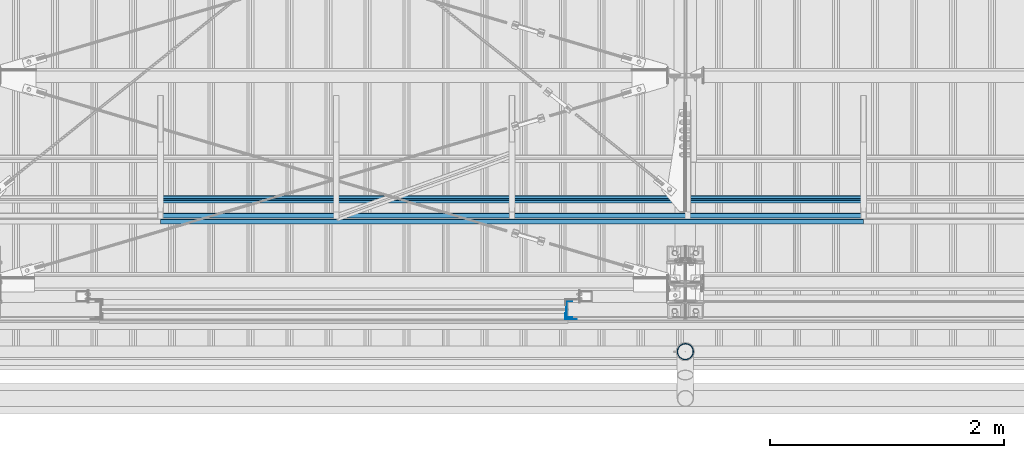
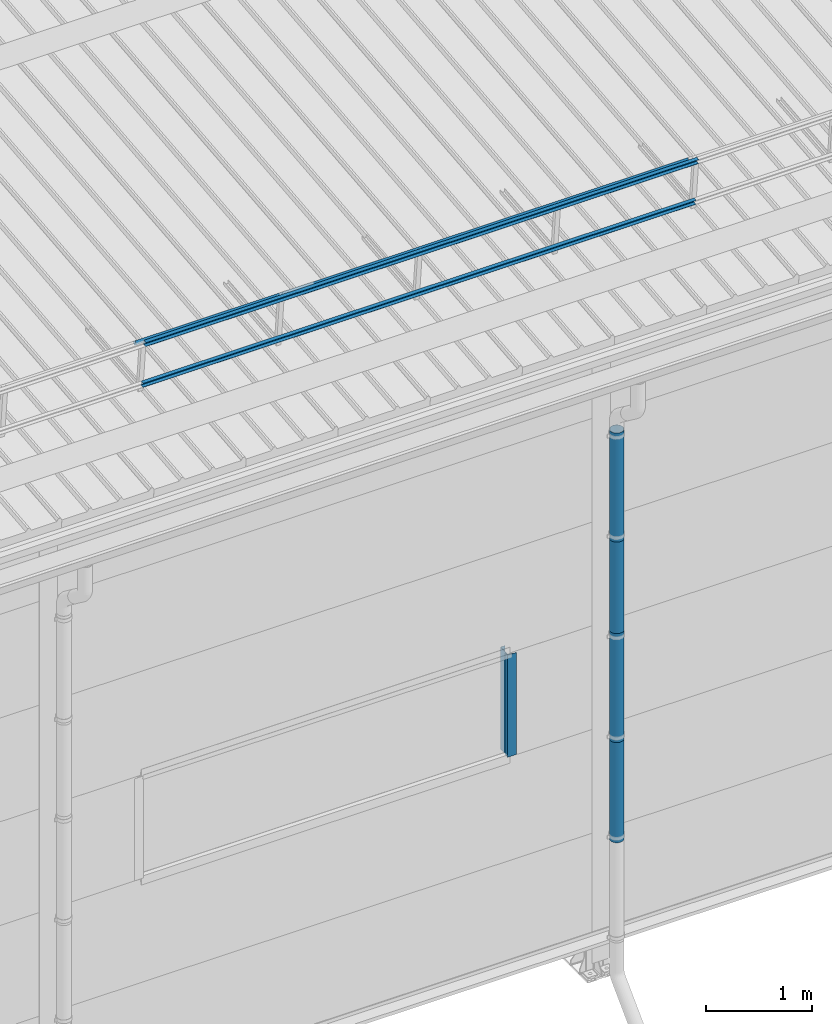
# One storey, part 36 of 709: 9 beams, 9 elements without a shape of their own.
"""IFC4 building model written with IfcOpenShell, lengths in millimetres."""

from ifc_helpers import new_model, si_unit, direction, frame, origin_with_axes, place, context, subcontext, project, spatial, line, indexed_curve, outline, extrude, material, element, aggregate, save


model = new_model("IFC4")

# Units and contexts
model_context = context("Model", 3, precision=0.2, world=origin_with_axes(), true_north=direction((0.0, 1.0)))
body_context = subcontext(model_context, "Body", "Model", "MODEL_VIEW")
ifc_project = project(units=[si_unit("LENGTHUNIT", "METRE", prefix="MILLI"), si_unit("AREAUNIT", "SQUARE_METRE"), si_unit("VOLUMEUNIT", "CUBIC_METRE"), si_unit("MASSUNIT", "GRAM", prefix="KILO"), si_unit("TIMEUNIT", "SECOND"), si_unit("PLANEANGLEUNIT", "RADIAN"), si_unit("SOLIDANGLEUNIT", "STERADIAN"), si_unit("THERMODYNAMICTEMPERATUREUNIT", "DEGREE_CELSIUS"), si_unit("LUMINOUSINTENSITYUNIT", "LUMEN")], contexts=[model_context])

# Site, building, storey
site_placement = place(None, origin_with_axes())
site = spatial("IfcSite", under=ifc_project, at=site_placement, CompositionType="ELEMENT")
building_placement = place(site_placement, origin_with_axes())
building = spatial("IfcBuilding", under=site, at=building_placement, Name="Undefined", CompositionType="ELEMENT")
storey_placement = place(building_placement, origin_with_axes())
storey = spatial("IfcBuildingStorey", under=building, at=storey_placement, Name="Undefined", CompositionType="ELEMENT", Elevation=0.0)

# Assembly, beam
assembly_1_placement = place(storey_placement, frame((5520.0, 691.31008, 8152.29341), z_axis=(0.0, -0.9950371902, -0.099503719), x_axis=(1.0, 0.0, 0.0)))
assembly_1 = element("IfcElementAssembly", 1, at=assembly_1_placement, inside=storey)
ifc_material = material(Name="Steel_Undefined", Category="STEEL")
beam_1_placement = place(assembly_1_placement, origin_with_axes())
beam_1 = element("IfcBeam", 2, at=beam_1_placement, material=ifc_material, ObjectType="606", context=body_context, shape_type="SolidModel", body=[
    extrude(outline(indexed_curve([(-20.0, -25.0), (20.0, -25.0), (20.0, -22.5), (-17.5, -22.5), (-17.5, 22.5), (20.0, 22.5), (20.0, 25.0), (-20.0, 25.0)], segments=[line(1, 2, 3, 4, 5, 6, 7, 8, 1)])), frame((0.0, 0.0, 0.0), z_axis=(-1.0, 0.0, 0.0), x_axis=(0.0, 0.0, 1.0)), (0.0, 0.0, -1.0), 6000.0),
])
aggregate(assembly_1, [beam_1])

assembly_2_placement = place(storey_placement, frame((5520.0, 741.06194, 7654.77481), z_axis=(0.0, -0.9950371902, -0.099503719), x_axis=(1.0, 0.0, 0.0)))
assembly_2 = element("IfcElementAssembly", 3, at=assembly_2_placement, inside=storey)
beam_2_placement = place(assembly_2_placement, origin_with_axes())
beam_2 = element("IfcBeam", 4, at=beam_2_placement, material=ifc_material, ObjectType="606", context=body_context, shape_type="SolidModel", body=[
    extrude(outline(indexed_curve([(-20.0, -25.0), (20.0, -25.0), (20.0, -22.5), (-17.5, -22.5), (-17.5, 22.5), (20.0, 22.5), (20.0, 25.0), (-20.0, 25.0)], segments=[line(1, 2, 3, 4, 5, 6, 7, 8, 1)])), frame((0.0, 0.0, 0.0), z_axis=(-1.0, 0.0, 0.0), x_axis=(0.0, 0.0, 1.0)), (0.0, 0.0, -1.0), 6000.0),
])
aggregate(assembly_2, [beam_2])

assembly_3_placement = place(storey_placement, frame((5520.0, 878.66704, 8043.11507), z_axis=(0.0, 0.6332377902, 0.7739572992), x_axis=(1.0, 0.0, 0.0)))
assembly_3 = element("IfcElementAssembly", 5, at=assembly_3_placement, inside=storey)
beam_3_placement = place(assembly_3_placement, origin_with_axes())
beam_3 = element("IfcBeam", 6, at=beam_3_placement, material=ifc_material, ObjectType="606", context=body_context, shape_type="SolidModel", body=[
    extrude(outline(indexed_curve([(-20.0, -25.0), (20.0, -25.0), (20.0, -22.5), (-17.5, -22.5), (-17.5, 22.5), (20.0, 22.5), (20.0, 25.0), (-20.0, 25.0)], segments=[line(1, 2, 3, 4, 5, 6, 7, 8, 1)])), frame((0.0, 0.0, 0.0), z_axis=(-1.0, 0.0, 0.0), x_axis=(0.0, 0.0, 1.0)), (0.0, 0.0, -1.0), 6000.0),
])
aggregate(assembly_3, [beam_3])

assembly_4_placement = place(storey_placement, frame((9010.0, -60.0, 3870.0), z_axis=(0.0, 1.0, 0.0), x_axis=(0.0, 0.0, -1.0)))
assembly_4 = element("IfcElementAssembly", 7, at=assembly_4_placement, inside=storey)
beam_4_placement = place(assembly_4_placement, origin_with_axes())
beam_4 = element("IfcBeam", 8, at=beam_4_placement, material=ifc_material, context=body_context, shape_type="SolidModel", body=[
    extrude(outline(indexed_curve([(-70.0, -25.0), (-68.0, -25.0), (-68.0, 23.0), (68.0, 23.0), (68.0, -25.0), (70.0, -25.0), (70.0, 25.0), (-70.0, 25.0)], segments=[line(1, 2, 3, 4, 5, 6, 7, 8, 1)])), frame((0.0, 0.0, 0.0), z_axis=(-1.0, 0.0, 0.0), x_axis=(0.0, 0.0, 1.0)), (0.0, 0.0, -1.0), 1170.0),
])
aggregate(assembly_4, [beam_4])

assembly_5_placement = place(storey_placement, frame((8975.0, -119.0, 3870.0), z_axis=(0.0, -1.0, 0.0), x_axis=(0.0, 0.0, -1.0)))
assembly_5 = element("IfcElementAssembly", 9, at=assembly_5_placement, inside=storey)
beam_5_placement = place(assembly_5_placement, origin_with_axes())
beam_5 = element("IfcBeam", 10, at=beam_5_placement, material=ifc_material, context=body_context, shape_type="SolidModel", body=[
    extrude(outline(indexed_curve([(-25.0, -1.0), (25.0, -1.0), (25.0, 99.0), (23.0, 99.0), (23.0, 1.0), (-25.0, 1.0)], segments=[line(1, 2, 3, 4, 5, 6, 1)])), frame((0.0, 0.0, 0.0), z_axis=(-1.0, 0.0, 0.0), x_axis=(0.0, 0.0, 1.0)), (0.0, 0.0, -1.0), 1170.0),
])
aggregate(assembly_5, [beam_5])

assembly_6_placement = place(storey_placement, frame((10000.0, -420.0, 6276.92297), z_axis=(0.0, 1.0, 0.0), x_axis=(0.0, 0.0, -1.0)))
assembly_6 = element("IfcElementAssembly", 11, at=assembly_6_placement, inside=storey)
beam_6_placement = place(assembly_6_placement, origin_with_axes())
beam_6 = element("IfcBeam", 12, at=beam_6_placement, material=ifc_material, ObjectType="614", context=body_context, shape_type="SolidModel", body=[
    extrude(outline(indexed_curve([(70.0, 0.0), (69.61653, 7.31699), (68.47033, 14.55382), (66.57396, 21.63119), (63.94818, 28.47157), (60.62178, 35.0), (56.63119, 41.14497), (52.02014, 46.83914), (46.83914, 52.02014), (41.14497, 56.63119), (35.0, 60.62178), (28.47157, 63.94818), (21.63119, 66.57396), (14.55382, 68.47033), (7.31699, 69.61653), (0.0, 70.0), (-7.31699, 69.61653), (-14.55382, 68.47033), (-21.63119, 66.57396), (-28.47157, 63.94818), (-35.0, 60.62178), (-41.14497, 56.63119), (-46.83914, 52.02014), (-52.02014, 46.83914), (-56.63119, 41.14497), (-60.62178, 35.0), (-63.94818, 28.47157), (-66.57396, 21.63119), (-68.47033, 14.55382), (-69.61653, 7.31699), (-70.0, 0.0), (-69.61653, -7.31699), (-68.47033, -14.55382), (-66.57396, -21.63119), (-63.94818, -28.47157), (-60.62178, -35.0), (-56.63119, -41.14497), (-52.02014, -46.83914), (-46.83914, -52.02014), (-41.14497, -56.63119), (-35.0, -60.62178), (-28.47157, -63.94818), (-21.63119, -66.57396), (-14.55382, -68.47033), (-7.31699, -69.61653), (0.0, -70.0), (7.31699, -69.61653), (14.55382, -68.47033), (21.63119, -66.57396), (28.47157, -63.94818), (35.0, -60.62178), (41.14497, -56.63119), (46.83914, -52.02014), (52.02014, -46.83914), (56.63119, -41.14497), (60.62178, -35.0), (63.94818, -28.47157), (66.57396, -21.63119), (68.47033, -14.55382), (69.61653, -7.31699)], segments=[line(1, 2, 3, 4, 5, 6, 7, 8, 9, 10, 11, 12, 13, 14, 15, 16, 17, 18, 19, 20, 21, 22, 23, 24, 25, 26, 27, 28, 29, 30, 31, 32, 33, 34, 35, 36, 37, 38, 39, 40, 41, 42, 43, 44, 45, 46, 47, 48, 49, 50, 51, 52, 53, 54, 55, 56, 57, 58, 59, 60, 1)]), holes=[indexed_curve([(65.0, 0.0), (64.64392, -6.79435), (63.57959, -13.51426), (61.81867, -20.0861), (59.38045, -26.43788), (56.29165, -32.5), (52.5861, -38.20604), (48.30441, -43.49349), (43.49349, -48.30441), (38.20604, -52.5861), (32.5, -56.29165), (26.43788, -59.38045), (20.0861, -61.81867), (13.51426, -63.57959), (6.79435, -64.64392), (0.0, -65.0), (-6.79435, -64.64392), (-13.51426, -63.57959), (-20.0861, -61.81867), (-26.43788, -59.38045), (-32.5, -56.29165), (-38.20604, -52.5861), (-43.49349, -48.30441), (-48.30441, -43.49349), (-52.5861, -38.20604), (-56.29165, -32.5), (-59.38045, -26.43788), (-61.81867, -20.0861), (-63.57959, -13.51426), (-64.64392, -6.79435), (-65.0, 0.0), (-64.64392, 6.79435), (-63.57959, 13.51426), (-61.81867, 20.0861), (-59.38045, 26.43788), (-56.29165, 32.5), (-52.5861, 38.20604), (-48.30441, 43.49349), (-43.49349, 48.30441), (-38.20604, 52.5861), (-32.5, 56.29165), (-26.43788, 59.38045), (-20.0861, 61.81867), (-13.51426, 63.57959), (-6.79435, 64.64392), (0.0, 65.0), (6.79435, 64.64392), (13.51426, 63.57959), (20.0861, 61.81867), (26.43788, 59.38045), (32.5, 56.29165), (38.20604, 52.5861), (43.49349, 48.30441), (48.30441, 43.49349), (52.5861, 38.20604), (56.29165, 32.5), (59.38045, 26.43788), (61.81867, 20.0861), (63.57959, 13.51426), (64.64392, 6.79435)], segments=[line(1, 2, 3, 4, 5, 6, 7, 8, 9, 10, 11, 12, 13, 14, 15, 16, 17, 18, 19, 20, 21, 22, 23, 24, 25, 26, 27, 28, 29, 30, 31, 32, 33, 34, 35, 36, 37, 38, 39, 40, 41, 42, 43, 44, 45, 46, 47, 48, 49, 50, 51, 52, 53, 54, 55, 56, 57, 58, 59, 60, 1)])]), frame((0.0, 0.0, 0.0), z_axis=(-1.0, 0.0, 0.0), x_axis=(0.0, 0.0, 1.0)), (0.0, 0.0, -1.0), 1250.0),
])
aggregate(assembly_6, [beam_6])

assembly_7_placement = place(storey_placement, frame((10000.0, -420.0, 5126.92297), z_axis=(0.0, 1.0, 0.0), x_axis=(0.0, 0.0, -1.0)))
assembly_7 = element("IfcElementAssembly", 13, at=assembly_7_placement, inside=storey)
beam_7_placement = place(assembly_7_placement, origin_with_axes())
beam_7 = element("IfcBeam", 14, at=beam_7_placement, material=ifc_material, ObjectType="614", context=body_context, shape_type="SolidModel", body=[
    extrude(outline(indexed_curve([(70.0, 0.0), (69.61653, 7.31699), (68.47033, 14.55382), (66.57396, 21.63119), (63.94818, 28.47157), (60.62178, 35.0), (56.63119, 41.14497), (52.02014, 46.83914), (46.83914, 52.02014), (41.14497, 56.63119), (35.0, 60.62178), (28.47157, 63.94818), (21.63119, 66.57396), (14.55382, 68.47033), (7.31699, 69.61653), (0.0, 70.0), (-7.31699, 69.61653), (-14.55382, 68.47033), (-21.63119, 66.57396), (-28.47157, 63.94818), (-35.0, 60.62178), (-41.14497, 56.63119), (-46.83914, 52.02014), (-52.02014, 46.83914), (-56.63119, 41.14497), (-60.62178, 35.0), (-63.94818, 28.47157), (-66.57396, 21.63119), (-68.47033, 14.55382), (-69.61653, 7.31699), (-70.0, 0.0), (-69.61653, -7.31699), (-68.47033, -14.55382), (-66.57396, -21.63119), (-63.94818, -28.47157), (-60.62178, -35.0), (-56.63119, -41.14497), (-52.02014, -46.83914), (-46.83914, -52.02014), (-41.14497, -56.63119), (-35.0, -60.62178), (-28.47157, -63.94818), (-21.63119, -66.57396), (-14.55382, -68.47033), (-7.31699, -69.61653), (0.0, -70.0), (7.31699, -69.61653), (14.55382, -68.47033), (21.63119, -66.57396), (28.47157, -63.94818), (35.0, -60.62178), (41.14497, -56.63119), (46.83914, -52.02014), (52.02014, -46.83914), (56.63119, -41.14497), (60.62178, -35.0), (63.94818, -28.47157), (66.57396, -21.63119), (68.47033, -14.55382), (69.61653, -7.31699)], segments=[line(1, 2, 3, 4, 5, 6, 7, 8, 9, 10, 11, 12, 13, 14, 15, 16, 17, 18, 19, 20, 21, 22, 23, 24, 25, 26, 27, 28, 29, 30, 31, 32, 33, 34, 35, 36, 37, 38, 39, 40, 41, 42, 43, 44, 45, 46, 47, 48, 49, 50, 51, 52, 53, 54, 55, 56, 57, 58, 59, 60, 1)]), holes=[indexed_curve([(65.0, 0.0), (64.64392, -6.79435), (63.57959, -13.51426), (61.81867, -20.0861), (59.38045, -26.43788), (56.29165, -32.5), (52.5861, -38.20604), (48.30441, -43.49349), (43.49349, -48.30441), (38.20604, -52.5861), (32.5, -56.29165), (26.43788, -59.38045), (20.0861, -61.81867), (13.51426, -63.57959), (6.79435, -64.64392), (0.0, -65.0), (-6.79435, -64.64392), (-13.51426, -63.57959), (-20.0861, -61.81867), (-26.43788, -59.38045), (-32.5, -56.29165), (-38.20604, -52.5861), (-43.49349, -48.30441), (-48.30441, -43.49349), (-52.5861, -38.20604), (-56.29165, -32.5), (-59.38045, -26.43788), (-61.81867, -20.0861), (-63.57959, -13.51426), (-64.64392, -6.79435), (-65.0, 0.0), (-64.64392, 6.79435), (-63.57959, 13.51426), (-61.81867, 20.0861), (-59.38045, 26.43788), (-56.29165, 32.5), (-52.5861, 38.20604), (-48.30441, 43.49349), (-43.49349, 48.30441), (-38.20604, 52.5861), (-32.5, 56.29165), (-26.43788, 59.38045), (-20.0861, 61.81867), (-13.51426, 63.57959), (-6.79435, 64.64392), (0.0, 65.0), (6.79435, 64.64392), (13.51426, 63.57959), (20.0861, 61.81867), (26.43788, 59.38045), (32.5, 56.29165), (38.20604, 52.5861), (43.49349, 48.30441), (48.30441, 43.49349), (52.5861, 38.20604), (56.29165, 32.5), (59.38045, 26.43788), (61.81867, 20.0861), (63.57959, 13.51426), (64.64392, 6.79435)], segments=[line(1, 2, 3, 4, 5, 6, 7, 8, 9, 10, 11, 12, 13, 14, 15, 16, 17, 18, 19, 20, 21, 22, 23, 24, 25, 26, 27, 28, 29, 30, 31, 32, 33, 34, 35, 36, 37, 38, 39, 40, 41, 42, 43, 44, 45, 46, 47, 48, 49, 50, 51, 52, 53, 54, 55, 56, 57, 58, 59, 60, 1)])]), frame((0.0, 0.0, 0.0), z_axis=(-1.0, 0.0, 0.0), x_axis=(0.0, 0.0, 1.0)), (0.0, 0.0, -1.0), 1250.0),
])
aggregate(assembly_7, [beam_7])

assembly_8_placement = place(storey_placement, frame((10000.0, -420.0, 3976.92297), z_axis=(0.0, 1.0, 0.0), x_axis=(0.0, 0.0, -1.0)))
assembly_8 = element("IfcElementAssembly", 15, at=assembly_8_placement, inside=storey)
beam_8_placement = place(assembly_8_placement, origin_with_axes())
beam_8 = element("IfcBeam", 16, at=beam_8_placement, material=ifc_material, ObjectType="614", context=body_context, shape_type="SolidModel", body=[
    extrude(outline(indexed_curve([(70.0, 0.0), (69.61653, 7.31699), (68.47033, 14.55382), (66.57396, 21.63119), (63.94818, 28.47157), (60.62178, 35.0), (56.63119, 41.14497), (52.02014, 46.83914), (46.83914, 52.02014), (41.14497, 56.63119), (35.0, 60.62178), (28.47157, 63.94818), (21.63119, 66.57396), (14.55382, 68.47033), (7.31699, 69.61653), (0.0, 70.0), (-7.31699, 69.61653), (-14.55382, 68.47033), (-21.63119, 66.57396), (-28.47157, 63.94818), (-35.0, 60.62178), (-41.14497, 56.63119), (-46.83914, 52.02014), (-52.02014, 46.83914), (-56.63119, 41.14497), (-60.62178, 35.0), (-63.94818, 28.47157), (-66.57396, 21.63119), (-68.47033, 14.55382), (-69.61653, 7.31699), (-70.0, 0.0), (-69.61653, -7.31699), (-68.47033, -14.55382), (-66.57396, -21.63119), (-63.94818, -28.47157), (-60.62178, -35.0), (-56.63119, -41.14497), (-52.02014, -46.83914), (-46.83914, -52.02014), (-41.14497, -56.63119), (-35.0, -60.62178), (-28.47157, -63.94818), (-21.63119, -66.57396), (-14.55382, -68.47033), (-7.31699, -69.61653), (0.0, -70.0), (7.31699, -69.61653), (14.55382, -68.47033), (21.63119, -66.57396), (28.47157, -63.94818), (35.0, -60.62178), (41.14497, -56.63119), (46.83914, -52.02014), (52.02014, -46.83914), (56.63119, -41.14497), (60.62178, -35.0), (63.94818, -28.47157), (66.57396, -21.63119), (68.47033, -14.55382), (69.61653, -7.31699)], segments=[line(1, 2, 3, 4, 5, 6, 7, 8, 9, 10, 11, 12, 13, 14, 15, 16, 17, 18, 19, 20, 21, 22, 23, 24, 25, 26, 27, 28, 29, 30, 31, 32, 33, 34, 35, 36, 37, 38, 39, 40, 41, 42, 43, 44, 45, 46, 47, 48, 49, 50, 51, 52, 53, 54, 55, 56, 57, 58, 59, 60, 1)]), holes=[indexed_curve([(65.0, 0.0), (64.64392, -6.79435), (63.57959, -13.51426), (61.81867, -20.0861), (59.38045, -26.43788), (56.29165, -32.5), (52.5861, -38.20604), (48.30441, -43.49349), (43.49349, -48.30441), (38.20604, -52.5861), (32.5, -56.29165), (26.43788, -59.38045), (20.0861, -61.81867), (13.51426, -63.57959), (6.79435, -64.64392), (0.0, -65.0), (-6.79435, -64.64392), (-13.51426, -63.57959), (-20.0861, -61.81867), (-26.43788, -59.38045), (-32.5, -56.29165), (-38.20604, -52.5861), (-43.49349, -48.30441), (-48.30441, -43.49349), (-52.5861, -38.20604), (-56.29165, -32.5), (-59.38045, -26.43788), (-61.81867, -20.0861), (-63.57959, -13.51426), (-64.64392, -6.79435), (-65.0, 0.0), (-64.64392, 6.79435), (-63.57959, 13.51426), (-61.81867, 20.0861), (-59.38045, 26.43788), (-56.29165, 32.5), (-52.5861, 38.20604), (-48.30441, 43.49349), (-43.49349, 48.30441), (-38.20604, 52.5861), (-32.5, 56.29165), (-26.43788, 59.38045), (-20.0861, 61.81867), (-13.51426, 63.57959), (-6.79435, 64.64392), (0.0, 65.0), (6.79435, 64.64392), (13.51426, 63.57959), (20.0861, 61.81867), (26.43788, 59.38045), (32.5, 56.29165), (38.20604, 52.5861), (43.49349, 48.30441), (48.30441, 43.49349), (52.5861, 38.20604), (56.29165, 32.5), (59.38045, 26.43788), (61.81867, 20.0861), (63.57959, 13.51426), (64.64392, 6.79435)], segments=[line(1, 2, 3, 4, 5, 6, 7, 8, 9, 10, 11, 12, 13, 14, 15, 16, 17, 18, 19, 20, 21, 22, 23, 24, 25, 26, 27, 28, 29, 30, 31, 32, 33, 34, 35, 36, 37, 38, 39, 40, 41, 42, 43, 44, 45, 46, 47, 48, 49, 50, 51, 52, 53, 54, 55, 56, 57, 58, 59, 60, 1)])]), frame((0.0, 0.0, 0.0), z_axis=(-1.0, 0.0, 0.0), x_axis=(0.0, 0.0, 1.0)), (0.0, 0.0, -1.0), 1250.0),
])
aggregate(assembly_8, [beam_8])

assembly_9_placement = place(storey_placement, frame((10000.0, -420.0, 2826.92297), z_axis=(0.0, 1.0, 0.0), x_axis=(0.0, 0.0, -1.0)))
assembly_9 = element("IfcElementAssembly", 17, at=assembly_9_placement, inside=storey)
beam_9_placement = place(assembly_9_placement, origin_with_axes())
beam_9 = element("IfcBeam", 18, at=beam_9_placement, material=ifc_material, ObjectType="614", context=body_context, shape_type="SolidModel", body=[
    extrude(outline(indexed_curve([(70.0, 0.0), (69.61653, 7.31699), (68.47033, 14.55382), (66.57396, 21.63119), (63.94818, 28.47157), (60.62178, 35.0), (56.63119, 41.14497), (52.02014, 46.83914), (46.83914, 52.02014), (41.14497, 56.63119), (35.0, 60.62178), (28.47157, 63.94818), (21.63119, 66.57396), (14.55382, 68.47033), (7.31699, 69.61653), (0.0, 70.0), (-7.31699, 69.61653), (-14.55382, 68.47033), (-21.63119, 66.57396), (-28.47157, 63.94818), (-35.0, 60.62178), (-41.14497, 56.63119), (-46.83914, 52.02014), (-52.02014, 46.83914), (-56.63119, 41.14497), (-60.62178, 35.0), (-63.94818, 28.47157), (-66.57396, 21.63119), (-68.47033, 14.55382), (-69.61653, 7.31699), (-70.0, 0.0), (-69.61653, -7.31699), (-68.47033, -14.55382), (-66.57396, -21.63119), (-63.94818, -28.47157), (-60.62178, -35.0), (-56.63119, -41.14497), (-52.02014, -46.83914), (-46.83914, -52.02014), (-41.14497, -56.63119), (-35.0, -60.62178), (-28.47157, -63.94818), (-21.63119, -66.57396), (-14.55382, -68.47033), (-7.31699, -69.61653), (0.0, -70.0), (7.31699, -69.61653), (14.55382, -68.47033), (21.63119, -66.57396), (28.47157, -63.94818), (35.0, -60.62178), (41.14497, -56.63119), (46.83914, -52.02014), (52.02014, -46.83914), (56.63119, -41.14497), (60.62178, -35.0), (63.94818, -28.47157), (66.57396, -21.63119), (68.47033, -14.55382), (69.61653, -7.31699)], segments=[line(1, 2, 3, 4, 5, 6, 7, 8, 9, 10, 11, 12, 13, 14, 15, 16, 17, 18, 19, 20, 21, 22, 23, 24, 25, 26, 27, 28, 29, 30, 31, 32, 33, 34, 35, 36, 37, 38, 39, 40, 41, 42, 43, 44, 45, 46, 47, 48, 49, 50, 51, 52, 53, 54, 55, 56, 57, 58, 59, 60, 1)]), holes=[indexed_curve([(65.0, 0.0), (64.64392, -6.79435), (63.57959, -13.51426), (61.81867, -20.0861), (59.38045, -26.43788), (56.29165, -32.5), (52.5861, -38.20604), (48.30441, -43.49349), (43.49349, -48.30441), (38.20604, -52.5861), (32.5, -56.29165), (26.43788, -59.38045), (20.0861, -61.81867), (13.51426, -63.57959), (6.79435, -64.64392), (0.0, -65.0), (-6.79435, -64.64392), (-13.51426, -63.57959), (-20.0861, -61.81867), (-26.43788, -59.38045), (-32.5, -56.29165), (-38.20604, -52.5861), (-43.49349, -48.30441), (-48.30441, -43.49349), (-52.5861, -38.20604), (-56.29165, -32.5), (-59.38045, -26.43788), (-61.81867, -20.0861), (-63.57959, -13.51426), (-64.64392, -6.79435), (-65.0, 0.0), (-64.64392, 6.79435), (-63.57959, 13.51426), (-61.81867, 20.0861), (-59.38045, 26.43788), (-56.29165, 32.5), (-52.5861, 38.20604), (-48.30441, 43.49349), (-43.49349, 48.30441), (-38.20604, 52.5861), (-32.5, 56.29165), (-26.43788, 59.38045), (-20.0861, 61.81867), (-13.51426, 63.57959), (-6.79435, 64.64392), (0.0, 65.0), (6.79435, 64.64392), (13.51426, 63.57959), (20.0861, 61.81867), (26.43788, 59.38045), (32.5, 56.29165), (38.20604, 52.5861), (43.49349, 48.30441), (48.30441, 43.49349), (52.5861, 38.20604), (56.29165, 32.5), (59.38045, 26.43788), (61.81867, 20.0861), (63.57959, 13.51426), (64.64392, 6.79435)], segments=[line(1, 2, 3, 4, 5, 6, 7, 8, 9, 10, 11, 12, 13, 14, 15, 16, 17, 18, 19, 20, 21, 22, 23, 24, 25, 26, 27, 28, 29, 30, 31, 32, 33, 34, 35, 36, 37, 38, 39, 40, 41, 42, 43, 44, 45, 46, 47, 48, 49, 50, 51, 52, 53, 54, 55, 56, 57, 58, 59, 60, 1)])]), frame((0.0, 0.0, 0.0), z_axis=(-1.0, 0.0, 0.0), x_axis=(0.0, 0.0, 1.0)), (0.0, 0.0, -1.0), 1250.0),
])
aggregate(assembly_9, [beam_9])

save(model, "model.ifc")
